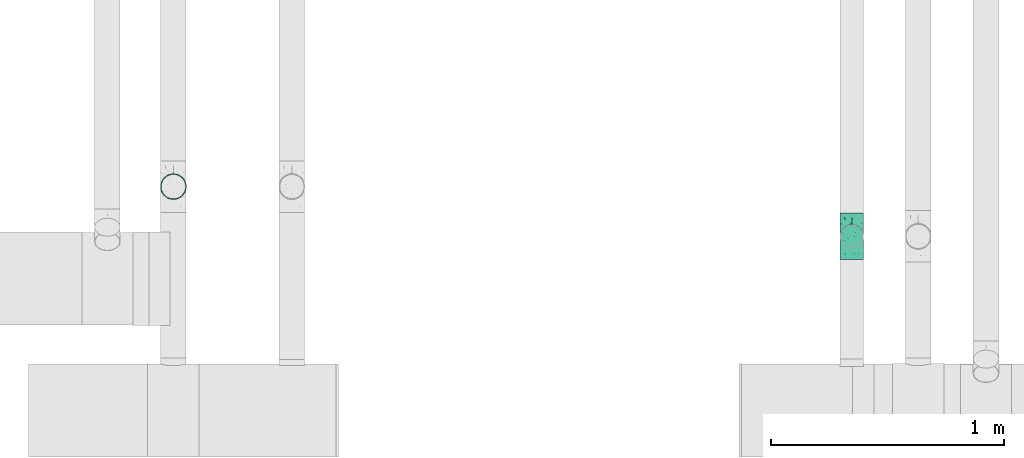
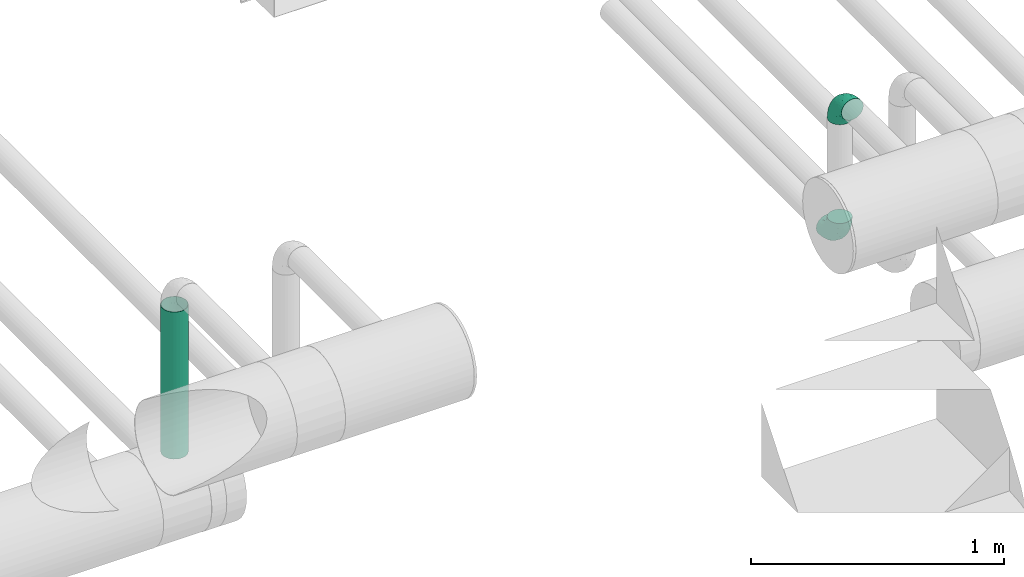
# One storey, part 75 of 91: 2 flow fittings, 1 flow segment.
"""IFC2X3 building model written with IfcOpenShell, lengths in millimetres."""

from ifc_helpers import new_model, entity, si_unit, converted_unit, derived_unit, direction, frame, origin_with_axes, origin_2d_with_axis, place, context, subcontext, project, spatial, hollow_circle, extrude, open_shell, surface_model, source, transform, mapped, material, layer, layer_set, layer_usage, type_object, element, save


model = new_model("IFC2X3")

# Units and contexts
model_context = context("Model", 3, precision=1e-05, world=origin_with_axes(), true_north=direction((0.0, 1.0)))
body_context = subcontext(model_context, "Body", "Model", "MODEL_VIEW")
ifc_project = project(units=[si_unit("AREAUNIT", "SQUARE_METRE"), si_unit("VOLUMEUNIT", "CUBIC_METRE", prefix="DECI"), si_unit("TIMEUNIT", "SECOND"), si_unit("THERMODYNAMICTEMPERATUREUNIT", "DEGREE_CELSIUS"), si_unit("PRESSUREUNIT", "PASCAL"), si_unit("MASSUNIT", "GRAM", prefix="KILO"), si_unit("LENGTHUNIT", "METRE", prefix="MILLI"), si_unit("POWERUNIT", "WATT"), si_unit("ELECTRICCURRENTUNIT", "AMPERE"), si_unit("ELECTRICVOLTAGEUNIT", "VOLT"), derived_unit("VOLUMETRICFLOWRATEUNIT", [(si_unit("VOLUMEUNIT", "CUBIC_METRE", prefix="DECI"), 1), (si_unit("TIMEUNIT", "SECOND"), -1)]), derived_unit("LINEARVELOCITYUNIT", [(si_unit("LENGTHUNIT", "METRE"), 1), (si_unit("TIMEUNIT", "SECOND"), -1)]), derived_unit("MASSDENSITYUNIT", [(si_unit("MASSUNIT", "GRAM", prefix="KILO"), 1), (si_unit("VOLUMEUNIT", "CUBIC_METRE"), -1)]), converted_unit("PLANEANGLEUNIT", "DEGREE", entity("IfcRatioMeasure", 0.01745), si_unit("PLANEANGLEUNIT", "RADIAN"), dimensions=[0, 0, 0, 0, 0, 0, 0])], contexts=[model_context])

# Site, building, storey
site_placement = place(None, origin_with_axes())
site = spatial("IfcSite", under=ifc_project, at=site_placement, CompositionType="ELEMENT")
building_placement = place(site_placement, origin_with_axes())
building = spatial("IfcBuilding", under=site, at=building_placement, Name="mc-building", CompositionType="ELEMENT")
storey_placement = place(building_placement, frame((0.0, 0.0, 8700.0), z_axis=(0.0, 0.0, 1.0), x_axis=(1.0, 0.0, 0.0)))
storey = spatial("IfcBuildingStorey", under=building, at=storey_placement, CompositionType="ELEMENT", Elevation=8700.0)

# Flow fittings
duct_fitting_type = type_object("IfcDuctFittingType", Name="BU", PredefinedType="BEND")
shared_shape_1 = source(origin_with_axes(), body_context, "Body", "SurfaceModel", [
    surface_model("IfcShellBasedSurfaceModel", [(-100.0, 0.0, -50.0), (-100.0, -12.94095, -48.29629), (-100.0, 12.94095, -48.29629), (-100.0, 48.29629, 12.94095), (-100.0, 25.0, -43.30127), (-100.0, 43.30127, -25.0), (-100.0, 35.35534, -35.35534), (-100.0, -50.0, 0.0), (-100.0, -48.29629, 12.94095), (-100.0, -35.35534, -35.35534), (-100.0, -25.0, -43.30127), (-100.0, -48.29629, -12.94095), (-100.0, -43.30127, -25.0), (-100.0, 48.29629, -12.94095), (-100.0, 43.30127, 25.0), (-100.0, 35.35534, 35.35534), (-100.0, -12.94095, 48.29629), (-100.0, 25.0, 43.30127), (-100.0, 12.94095, 48.29629), (-100.0, -43.30127, 25.0), (-100.0, -35.35534, 35.35534), (-100.0, -25.0, 43.30127), (-100.0, 0.0, 50.0), (-100.0, 50.0, 0.0), (-12.94095, 100.0, -48.29629), (-50.0, 100.0, 0.0), (0.0, 100.0, -50.0), (-25.0, 100.0, -43.30127), (-35.35534, 100.0, -35.35534), (-43.30127, 100.0, -25.0), (35.35534, 100.0, -35.35534), (48.29629, 100.0, 12.94095), (25.0, 100.0, -43.30127), (12.94095, 100.0, -48.29629), (43.30127, 100.0, -25.0), (48.29629, 100.0, -12.94095), (50.0, 100.0, 0.0), (-48.29629, 100.0, -12.94095), (-48.29629, 100.0, 12.94095), (-43.30127, 100.0, 25.0), (-35.35534, 100.0, 35.35534), (0.0, 100.0, 50.0), (-25.0, 100.0, 43.30127), (-12.94095, 100.0, 48.29629), (43.30127, 100.0, 25.0), (35.35534, 100.0, 35.35534), (25.0, 100.0, 43.30127), (12.94095, 100.0, 48.29629), (-58.37939, 44.26324, 39.66767), (-69.67318, 34.70921, 41.41807), (-54.95374, 29.60867, 47.22379), (-69.0983, 4.89435, 50.0), (-81.95957, 10.85813, 49.17398), (-71.45436, 24.34004, 46.19398), (-63.80701, 16.86512, 49.12211), (-68.68567, 49.28345, 29.46598), (-84.79657, 41.61468, 30.43807), (-87.38486, 20.12422, 46.19398), (-19.0983, 41.22148, 50.0), (-16.69326, 64.07661, 49.13167), (-29.12893, 54.21835, 47.49497), (-58.07867, 67.98053, 16.35576), (-67.87621, 57.34916, 18.11021), (-57.82431, 60.07162, 27.24983), (-90.54273, 47.92896, 16.84479), (-84.64671, 51.44953, 9.54872), (-89.28706, 52.13093, 0.0), (-48.57141, 84.18266, 19.13417), (-80.49866, 49.85236, 19.13417), (-10.78328, 82.03604, 49.18466), (-4.89435, 69.0983, 50.0), (-52.13093, 89.28706, 0.0), (-51.49654, 84.66157, 9.29171), (-41.22148, 19.0983, 50.0), (-40.55308, 40.55308, 47.39468), (-84.25895, 32.24248, 39.66767), (-20.22969, 86.73423, 46.19398), (-32.70712, 82.37816, 39.66767), (-39.73574, 63.26064, 40.42863), (-24.76101, 70.36257, 46.19398), (-52.07527, 72.10209, 22.70672), (-53.34351, 76.64659, 14.58596), (-75.39343, 54.87419, 11.74349), (-45.34852, 49.56196, 42.93091), (-67.79776, 60.76145, 8.68857), (-41.23466, 86.33892, 30.43807), (-53.80602, 80.86583, 0.0), (-46.83364, 71.48109, 30.43807), (-59.22534, 72.75524, 0.0), (-51.32111, 56.42251, 36.03223), (-80.86583, 53.80602, 0.0), (-64.64466, 64.64466, 0.0), (-72.75524, 59.22534, 0.0), (-86.30081, 41.24353, -30.43807), (-84.6487, 51.45583, -9.51467), (-90.59087, 47.99544, -16.6365), (-82.00387, 32.80624, -39.66767), (-72.72667, 42.3343, -34.47953), (-69.0983, 4.89435, -50.0), (-66.13967, 17.89682, -48.73206), (-41.22148, 19.0983, -50.0), (-19.92688, 59.20071, -48.9627), (-4.89435, 69.0983, -50.0), (-19.0983, 41.22148, -50.0), (-32.19887, 84.44786, -39.66767), (-82.82099, 10.02515, -49.28938), (-41.61468, 84.79657, -30.43807), (-82.27704, 21.1002, -46.19398), (-64.48049, 30.28903, -45.01594), (-71.3903, 57.59661, -10.6727), (-22.65007, 76.4146, -46.19398), (-80.71765, 49.76775, -19.13417), (-63.27201, 52.13514, -30.43807), (-66.69474, 56.78794, -20.8562), (-57.71875, 61.44646, -25.88117), (-51.44953, 84.64671, -9.54872), (-49.85236, 80.49866, -19.13417), (-49.18799, 68.95983, -29.38061), (-52.50869, 28.2692, -48.00802), (-47.92896, 90.54273, -16.84479), (-11.48103, 81.33005, -49.0827), (-31.33477, 60.4193, -45.4939), (-39.98518, 39.98518, -47.65708), (-59.80479, 65.98498, -16.07996), (-63.94971, 39.6845, -40.19955), (-52.24546, 47.26788, -40.83149), (-55.20497, 74.81068, -11.71424), (-38.49923, 67.49589, -39.66767), (-52.04722, 57.72873, -34.6201), (-73.59404, 48.69992, -26.65479), (-47.57173, 4.1387, -49.13473), (29.5722, 42.84907, -27.71428), (13.52969, 19.02651, -30.72245), (13.59601, 32.77977, -38.42312), (27.49134, 63.71843, -37.951), (17.59627, 59.41659, -43.64098), (-63.95523, -42.22253, -17.81382), (-42.84907, -29.5722, -27.71428), (-25.90272, -27.798, -14.9099), (-4.1387, 47.57173, -49.13473), (-20.45037, 20.45037, -48.41225), (-68.61243, -10.20497, -47.82471), (-73.92917, -46.87327, -9.07697), (-73.47057, -38.0442, -29.22414), (-63.71843, -27.49134, -37.951), (-32.77977, -13.59601, -38.42312), (-8.32573, -9.86545, -25.36336), (-59.41659, -17.59627, -43.64098), (10.20497, 68.61244, -47.82471), (3.58524, 39.93936, -45.93923), (-12.17948, 12.17948, -43.75507), (-39.93936, -3.58524, -45.93923), (44.88888, 61.17714, 0.0), (38.05536, 43.47505, -9.02401), (45.64165, 67.74269, -9.06645), (17.21028, 10.65055, -15.96581), (-25.0, -29.90381, 0.0), (-1.12135, -11.13977, -11.07369), (38.0442, 73.47057, -29.22414), (32.46004, 37.55825, -18.52941), (42.22253, 63.95523, -17.81382), (29.90381, 25.0, 0.0), (6.06602, -6.06602, 0.0), (-61.17714, -44.88888, 0.0), (-45.78423, -39.05041, -8.65056), (-4.97501, 4.97501, -36.29915), (-63.95523, -42.22253, 17.81382), (-67.74269, -45.64165, 9.06645), (-37.55825, -32.46004, 18.52941), (-42.84907, -29.5722, 27.71428), (-73.47057, -38.0442, 29.22414), (-4.1387, 47.57173, 49.13473), (10.20497, 68.61244, 47.82471), (-39.93936, -3.58524, 45.93923), (-59.41659, -17.59627, 43.64098), (-32.77977, -13.59601, 38.42312), (-63.71843, -27.49134, 37.951), (-10.65055, -17.21028, 15.96581), (27.798, 25.90272, 14.9099), (11.13977, 1.12135, 11.07369), (46.87327, 73.92917, 9.07697), (39.05041, 45.78423, 8.65056), (-68.61243, -10.20497, 47.82471), (-47.57173, 4.1387, 49.13473), (3.58524, 39.93936, 45.93923), (-20.45037, 20.45037, 48.41225), (-12.17948, 12.17948, 43.75507), (9.86545, 8.32574, 25.36336), (-19.02651, -13.52969, 30.72245), (-43.47505, -38.05536, 9.02401), (29.5722, 42.84907, 27.71428), (42.22253, 63.95523, 17.81382), (38.0442, 73.47057, 29.22414), (27.49134, 63.71843, 37.951), (17.59627, 59.41659, 43.64098), (13.59601, 32.77977, 38.42312), (-4.97501, 4.97501, 36.29915)], [open_shell([[[0, 1, 2]], [[2, 3, 4]], [[5, 6, 3]], [[3, 6, 4]], [[2, 7, 8]], [[9, 7, 10]], [[1, 10, 7]], [[11, 7, 12]], [[9, 12, 7]], [[7, 2, 1]], [[13, 5, 3]], [[14, 3, 2]], [[15, 14, 2]], [[16, 17, 2]], [[15, 2, 17]], [[18, 17, 16]], [[8, 19, 2]], [[2, 19, 20]], [[2, 20, 21]], [[16, 2, 21]], [[16, 22, 18]], [[23, 13, 3]], [[24, 25, 26]], [[27, 25, 24]], [[25, 28, 29]], [[27, 28, 25]], [[30, 26, 31]], [[26, 30, 32]], [[32, 33, 26]], [[30, 31, 34]], [[35, 34, 31]], [[35, 31, 36]], [[37, 25, 29]], [[26, 38, 39]], [[26, 39, 40]], [[41, 40, 42]], [[40, 41, 26]], [[41, 42, 43]], [[26, 44, 31]], [[45, 44, 26]], [[46, 45, 26]], [[47, 46, 26]], [[47, 26, 41]], [[26, 25, 38]], [[48, 49, 50]], [[22, 51, 52]], [[53, 54, 50]], [[55, 56, 49]], [[56, 14, 15]], [[18, 57, 17]], [[58, 59, 60]], [[61, 62, 63]], [[3, 64, 65]], [[53, 52, 54]], [[3, 65, 66]], [[67, 39, 38]], [[56, 68, 64]], [[65, 64, 68]], [[69, 59, 70]], [[38, 71, 72]], [[73, 58, 74]], [[75, 49, 56]], [[76, 69, 43]], [[53, 57, 52]], [[77, 78, 79]], [[42, 76, 43]], [[43, 69, 41]], [[55, 68, 56]], [[15, 17, 75]], [[76, 77, 79]], [[80, 67, 81]], [[62, 82, 68]], [[60, 78, 83]], [[62, 84, 82]], [[85, 77, 40]], [[81, 67, 72]], [[86, 72, 71]], [[87, 85, 67]], [[61, 81, 88]], [[77, 42, 40]], [[78, 77, 87]], [[15, 75, 56]], [[83, 89, 48]], [[85, 40, 39]], [[62, 68, 55]], [[89, 87, 63]], [[83, 48, 50]], [[57, 75, 17]], [[49, 75, 53]], [[67, 85, 39]], [[87, 77, 85]], [[63, 62, 55]], [[89, 55, 48]], [[80, 63, 87]], [[66, 65, 90]], [[66, 23, 3]], [[84, 91, 92]], [[92, 90, 82]], [[65, 82, 90]], [[61, 84, 62]], [[92, 82, 84]], [[68, 82, 65]], [[3, 14, 64]], [[56, 64, 14]], [[38, 25, 71]], [[81, 72, 86]], [[38, 72, 67]], [[91, 61, 88]], [[80, 81, 61]], [[63, 80, 61]], [[67, 80, 87]], [[77, 76, 42]], [[79, 59, 69]], [[79, 69, 76]], [[41, 69, 70]], [[60, 59, 79]], [[58, 70, 59]], [[78, 60, 79]], [[58, 60, 74]], [[52, 57, 18]], [[75, 57, 53]], [[22, 52, 18]], [[52, 51, 54]], [[51, 73, 54]], [[50, 73, 74]], [[73, 50, 54]], [[50, 74, 83]], [[60, 83, 74]], [[89, 83, 78]], [[87, 89, 78]], [[55, 89, 63]], [[50, 49, 53]], [[55, 49, 48]], [[81, 86, 88]], [[91, 84, 61]], [[6, 5, 93]], [[90, 94, 66]], [[13, 94, 95]], [[96, 93, 97]], [[98, 99, 100]], [[96, 4, 6]], [[101, 102, 103]], [[28, 27, 104]], [[2, 105, 0]], [[104, 106, 28]], [[99, 105, 107]], [[108, 107, 96]], [[90, 109, 94]], [[107, 2, 4]], [[13, 66, 94]], [[27, 24, 110]], [[109, 111, 94]], [[112, 113, 114]], [[37, 115, 71]], [[116, 106, 117]], [[99, 118, 100]], [[116, 115, 119]], [[37, 119, 115]], [[24, 120, 110]], [[121, 110, 101]], [[119, 106, 116]], [[101, 110, 120]], [[122, 103, 100]], [[117, 123, 116]], [[124, 125, 108]], [[115, 116, 126]], [[106, 29, 28]], [[26, 102, 120]], [[127, 104, 110]], [[97, 124, 96]], [[125, 122, 118]], [[128, 127, 125]], [[96, 6, 93]], [[115, 126, 86]], [[117, 106, 127]], [[111, 113, 129]], [[95, 93, 5]], [[97, 129, 112]], [[110, 104, 27]], [[106, 104, 127]], [[96, 107, 4]], [[99, 107, 108]], [[99, 108, 118]], [[105, 99, 98]], [[112, 114, 128]], [[121, 125, 127]], [[13, 23, 66]], [[109, 90, 92]], [[94, 111, 95]], [[91, 123, 109]], [[129, 113, 112]], [[93, 95, 111]], [[5, 13, 95]], [[71, 115, 86]], [[71, 25, 37]], [[123, 91, 88]], [[126, 116, 123]], [[123, 88, 126]], [[86, 126, 88]], [[37, 29, 119]], [[106, 119, 29]], [[129, 93, 111]], [[124, 112, 125]], [[0, 105, 98]], [[107, 105, 2]], [[125, 118, 108]], [[100, 118, 122]], [[93, 129, 97]], [[113, 111, 109]], [[109, 123, 113]], [[114, 123, 117]], [[123, 114, 113]], [[128, 114, 117]], [[127, 128, 117]], [[112, 128, 125]], [[103, 122, 101]], [[110, 121, 127]], [[101, 122, 121]], [[125, 121, 122]], [[26, 120, 24]], [[101, 120, 102]], [[96, 124, 108]], [[92, 91, 109]], [[112, 124, 97]], [[100, 130, 98]], [[131, 132, 133]], [[32, 134, 135]], [[136, 137, 138]], [[139, 140, 103]], [[98, 141, 0]], [[142, 11, 136]], [[143, 144, 137]], [[7, 11, 142]], [[137, 145, 146]], [[144, 147, 145]], [[143, 136, 12]], [[12, 136, 11]], [[9, 143, 12]], [[148, 149, 139]], [[9, 10, 144]], [[10, 1, 147]], [[130, 141, 98]], [[103, 140, 100]], [[148, 135, 149]], [[150, 151, 140]], [[152, 153, 154]], [[130, 140, 151]], [[148, 26, 33]], [[147, 1, 141]], [[155, 146, 132]], [[156, 138, 157]], [[134, 30, 158]], [[150, 140, 149]], [[158, 30, 34]], [[30, 134, 32]], [[153, 159, 160]], [[131, 160, 159]], [[144, 145, 137]], [[36, 152, 154]], [[146, 138, 137]], [[155, 161, 162]], [[158, 160, 131]], [[133, 149, 135]], [[156, 163, 164]], [[163, 142, 164]], [[139, 103, 102]], [[153, 152, 161]], [[34, 35, 160]], [[162, 157, 155]], [[132, 165, 133]], [[157, 146, 155]], [[140, 130, 100]], [[141, 130, 151]], [[141, 151, 147]], [[141, 1, 0]], [[102, 26, 148]], [[140, 139, 149]], [[102, 148, 139]], [[135, 33, 32]], [[151, 150, 145]], [[10, 147, 144]], [[151, 145, 147]], [[145, 165, 146]], [[135, 148, 33]], [[133, 135, 134]], [[131, 133, 134]], [[133, 165, 150]], [[133, 150, 149]], [[145, 150, 165]], [[132, 131, 159]], [[146, 165, 132]], [[160, 158, 34]], [[134, 158, 131]], [[144, 143, 9]], [[136, 143, 137]], [[155, 153, 161]], [[154, 153, 160]], [[153, 155, 159]], [[132, 159, 155]], [[160, 35, 154]], [[36, 154, 35]], [[164, 136, 138]], [[7, 142, 163]], [[136, 164, 142]], [[156, 164, 138]], [[156, 157, 162]], [[146, 157, 138]], [[19, 8, 166]], [[7, 163, 167]], [[168, 169, 166]], [[166, 169, 170]], [[171, 172, 70]], [[173, 174, 175]], [[21, 176, 174]], [[177, 156, 162]], [[176, 20, 170]], [[170, 20, 19]], [[161, 178, 179]], [[152, 180, 181]], [[182, 173, 183]], [[22, 16, 182]], [[184, 185, 186]], [[183, 185, 73]], [[183, 73, 51]], [[177, 187, 188]], [[189, 168, 166]], [[187, 178, 190]], [[20, 176, 21]], [[161, 152, 181]], [[44, 191, 31]], [[44, 45, 192]], [[192, 191, 44]], [[180, 36, 31]], [[193, 194, 195]], [[46, 47, 194]], [[193, 195, 190]], [[193, 45, 46]], [[172, 41, 70]], [[185, 58, 73]], [[189, 163, 156]], [[163, 189, 167]], [[70, 58, 171]], [[184, 171, 185]], [[169, 188, 175]], [[180, 31, 191]], [[192, 193, 190]], [[191, 190, 178]], [[182, 174, 173]], [[194, 47, 172]], [[190, 195, 187]], [[186, 185, 173]], [[162, 179, 177]], [[188, 196, 175]], [[179, 187, 177]], [[185, 171, 58]], [[172, 171, 184]], [[172, 184, 194]], [[172, 47, 41]], [[51, 22, 182]], [[185, 183, 173]], [[51, 182, 183]], [[174, 16, 21]], [[184, 186, 195]], [[46, 194, 193]], [[184, 195, 194]], [[195, 196, 187]], [[174, 182, 16]], [[175, 174, 176]], [[169, 175, 176]], [[175, 196, 186]], [[175, 186, 173]], [[195, 186, 196]], [[188, 169, 168]], [[187, 196, 188]], [[166, 170, 19]], [[176, 170, 169]], [[193, 192, 45]], [[191, 192, 190]], [[177, 189, 156]], [[167, 189, 166]], [[189, 177, 168]], [[188, 168, 177]], [[166, 8, 167]], [[7, 167, 8]], [[181, 191, 178]], [[36, 180, 152]], [[191, 181, 180]], [[161, 181, 178]], [[161, 179, 162]], [[187, 179, 178]]])]),
])
for number, where, z_axis, x_axis, name in (
    (1, (29312.94843, 10827.25695, 1344.0), (1.0, 0.0, 0.0), (0.0, 0.0, 1.0), "BU"),
    (2, (29312.94843, 10827.25695, 668.0), (-1.0, 0.0, 0.0), (0.0, -1.0, 0.0), "BU"),
):
    element("IfcFlowFitting", number, at=place(storey_placement, frame(where, z_axis=z_axis, x_axis=x_axis)), inside=storey, type_object=duct_fitting_type, Name=name, context=body_context, shape_type="MappedRepresentation", body=[
        mapped(shared_shape_1, transform((0.0, 0.0, 0.0), scale=1.0)),
    ])

# Flow segment
ifc_material = material(Name="FZ1")
ifc_layer = layer(ifc_material, 0.0)
ifc_layer_set = layer_set([ifc_layer], Name="FZ1")
ifc_layer_usage = layer_usage(ifc_layer_set, "AXIS1", "POSITIVE", 0.0)
duct_segment_type = type_object("IfcDuctSegmentType", PredefinedType="RIGIDSEGMENT")
shared_shape_2 = source(origin_with_axes(), body_context, "Body", "SweptSolid", [
    extrude(hollow_circle(Radius=55.0, WallThickness=2.0, at=origin_2d_with_axis()), frame((0.0, 0.0, 0.0), z_axis=(1.0, 0.0, 0.0), x_axis=(0.0, 1.0, 0.0)), (0.0, 0.0, 1.0), 709.0),
])
flow_segment_placement = place(storey_placement, frame((26403.5823, 11040.50687, 1234.0), z_axis=(0.0, 1.0, 0.0), x_axis=(0.0, 0.0, -1.0)))
element("IfcFlowSegment", 3, at=flow_segment_placement, inside=storey, type_object=duct_segment_type, material=ifc_layer_usage, context=body_context, shape_type="MappedRepresentation", body=[
    mapped(shared_shape_2, transform((0.0, 0.0, 0.0), scale=1.0)),
])

save(model, "model.ifc")
